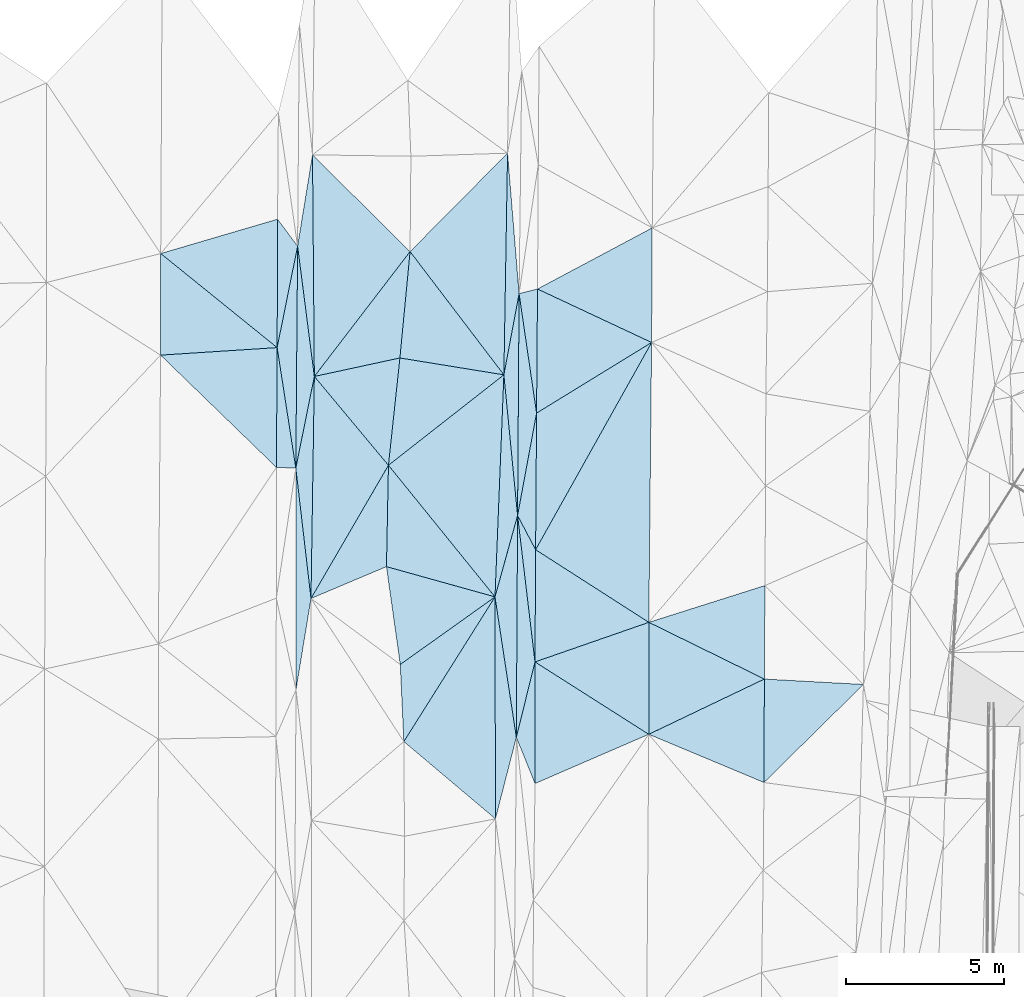
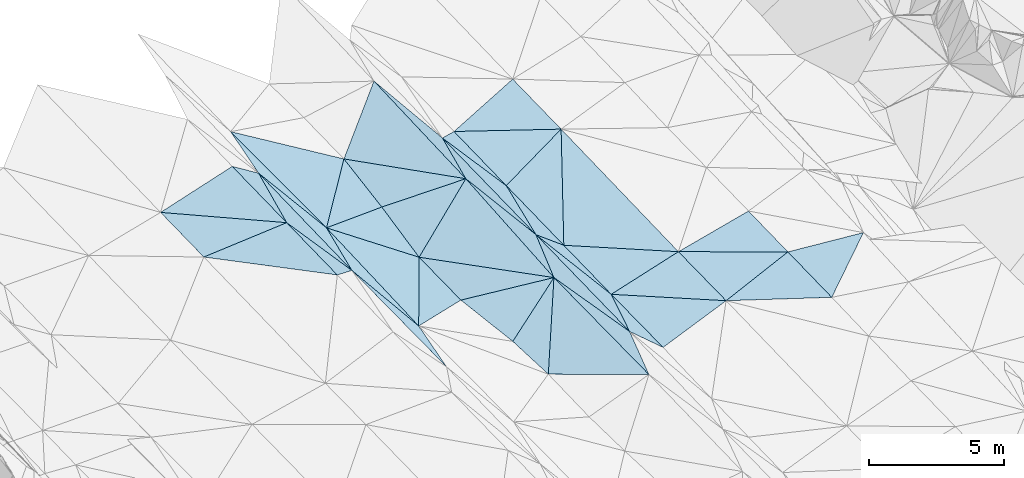
# One storey, part 148 of 275: 45 plates.
"""IFC2X3 building model written with IfcOpenShell, lengths in millimetres."""

from ifc_helpers import new_model, si_unit, frame, origin_with_axes, place, context, subcontext, project, spatial, polyline, outline, extrude, material, type_object, element, save


model = new_model("IFC2X3")

# Units and contexts
model_context = context("Model", 3, precision=1e-05, world=origin_with_axes())
body_context = subcontext(model_context, "Body", "Model", "MODEL_VIEW")
ifc_project = project(units=[si_unit("LENGTHUNIT", "METRE", prefix="MILLI"), si_unit("AREAUNIT", "SQUARE_METRE"), si_unit("VOLUMEUNIT", "CUBIC_METRE"), si_unit("MASSUNIT", "GRAM", prefix="KILO"), si_unit("TIMEUNIT", "SECOND"), si_unit("PLANEANGLEUNIT", "RADIAN"), si_unit("SOLIDANGLEUNIT", "STERADIAN"), si_unit("THERMODYNAMICTEMPERATUREUNIT", "DEGREE_CELSIUS"), si_unit("LUMINOUSINTENSITYUNIT", "LUMEN")], contexts=[model_context])

# Site, building, storey
site_placement = place(None, origin_with_axes())
site = spatial("IfcSite", under=ifc_project, at=site_placement, CompositionType="ELEMENT")
building_placement = place(site_placement, origin_with_axes())
building = spatial("IfcBuilding", under=site, at=building_placement, Name="Undefined", CompositionType="ELEMENT")
storey_placement = place(building_placement, origin_with_axes())
storey = spatial("IfcBuildingStorey", under=building, at=storey_placement, Name="Undefined", CompositionType="ELEMENT", Elevation=0.0)

# Plates
ifc_material = material()
plate_type_1 = type_object("IfcPlateType", PredefinedType="NOTDEFINED")
plate_1_placement = place(storey_placement, frame((-75964.6085799381, 115638.911751453, 43204.5066319559), z_axis=(0.160311117242028, 0.0261125572139905, -0.986721075098915), x_axis=(-0.0464081485364225, 0.998743920597506, 0.0188908660189011)))
element("IfcPlate", 1, at=plate_1_placement, inside=storey, type_object=plate_type_1, material=ifc_material, Name="00", context=body_context, shape_type="SweptSolid", body=[
    extrude(outline(polyline([(0.0, 0.0), (2435.03930664063, 3.14321368932724e-09), (4437.47998046875, 3125.26147460938), (0.0, 0.0)])), frame((-8.85201319254618e-08, 2.18876761149539e-07, -0.5000001331573), z_axis=(0.0, 0.0, 1.0), x_axis=(1.0, 0.0, 0.0)), (0.0, 0.0, 1.0), 1.0),
])
plate_type_2 = type_object("IfcPlateType", PredefinedType="NOTDEFINED")
plate_2_placement = place(storey_placement, frame((-79949.0426562773, 132120.246670613, 43989.5001166933), z_axis=(0.0107188924099907, 0.0197077235417985, -0.999748323818701), x_axis=(0.596220278596028, -0.802765477815505, -0.00943223295513346)))
element("IfcPlate", 2, at=plate_2_placement, inside=storey, type_object=plate_type_2, material=ifc_material, Name="00", context=body_context, shape_type="SweptSolid", body=[
    extrude(outline(polyline([(0.0, 0.0), (1060.1943359375, 1.47701939567924e-09), (3245.15991210938, 2426.48681640625), (0.0, 0.0)])), frame((-8.85201319254618e-08, 2.18876761149539e-07, -0.5000001331573), z_axis=(0.0, 0.0, 1.0), x_axis=(1.0, 0.0, 0.0)), (0.0, 0.0, 1.0), 1.0),
])
plate_type_3 = type_object("IfcPlateType", PredefinedType="NOTDEFINED")
plate_3_placement = place(storey_placement, frame((-79373.2008001047, 124268.647137265, 43851.5059641015), z_axis=(-0.152916196069069, 0.0192931900139735, -0.988050813368852), x_axis=(0.00802434047294629, 0.999800692518629, 0.0182807330062237)))
element("IfcPlate", 3, at=plate_3_placement, inside=storey, type_object=plate_type_3, material=ifc_material, Name="00", context=body_context, shape_type="SweptSolid", body=[
    extrude(outline(polyline([(0.0, 0.0), (7001.9072265625, -3.77476681023836e-08), (2893.5478515625, 567.798400878906), (0.0, 0.0)])), frame((-8.85201319254618e-08, 2.18876761149539e-07, -0.5000001331573), z_axis=(0.0, 0.0, 1.0), x_axis=(1.0, 0.0, 0.0)), (0.0, 0.0, 1.0), 1.0),
])
plate_type_4 = type_object("IfcPlateType", PredefinedType="NOTDEFINED")
plate_4_placement = place(storey_placement, frame((-61465.4492507407, 117441.521817981, 43429.500453023), z_axis=(-0.0371762981072988, 0.0215616423934602, -0.999076082406307), x_axis=(-0.712118536360222, -0.701967516282488, 0.0113488438340389)))
element("IfcPlate", 4, at=plate_4_placement, inside=storey, type_object=plate_type_4, material=ifc_material, Name="00", context=body_context, shape_type="SweptSolid", body=[
    extrude(outline(polyline([(0.0, 0.0), (4405.73486328125, -4.88944351673126e-09), (2107.61669921875, 2317.94140625), (0.0, 0.0)])), frame((-8.85201319254618e-08, 2.18876761149539e-07, -0.5000001331573), z_axis=(0.0, 0.0, 1.0), x_axis=(1.0, 0.0, 0.0)), (0.0, 0.0, 1.0), 1.0),
])
plate_type_5 = type_object("IfcPlateType", PredefinedType="NOTDEFINED")
plate_5_placement = place(storey_placement, frame((-73089.1088576157, 120204.461598305, 43792.5074478523), z_axis=(0.170969803398157, 0.0191893173481751, -0.985089384992908), x_axis=(0.00199426654865847, -0.999815014952442, -0.0191300490480677)))
element("IfcPlate", 5, at=plate_5_placement, inside=storey, type_object=plate_type_5, material=ifc_material, Name="00", context=body_context, shape_type="SweptSolid", body=[
    extrude(outline(polyline([(0.0, 0.0), (7004.68701171875, -2.03726813197136e-09), (4570.22265625, 2927.72143554688), (0.0, 0.0)])), frame((-8.85201319254618e-08, 2.18876761149539e-07, -0.5000001331573), z_axis=(0.0, 0.0, 1.0), x_axis=(1.0, 0.0, 0.0)), (0.0, 0.0, 1.0), 1.0),
])
plate_type_6 = type_object("IfcPlateType", PredefinedType="NOTDEFINED")
plate_6_placement = place(storey_placement, frame((-78894.5313013717, 120153.823342637, 43670.5076123488), z_axis=(-0.172369302595807, 0.0232650245499434, -0.984757615941774), x_axis=(-0.115441002584001, 0.992354758221715, 0.0436509880429174)))
element("IfcPlate", 6, at=plate_6_placement, inside=storey, type_object=plate_type_6, material=ifc_material, Name="00", context=body_context, shape_type="SweptSolid", body=[
    extrude(outline(polyline([(0.0, 0.0), (4146.52685546875, -1.03755155578256e-08), (6945.5498046875, 927.623901367188), (0.0, 0.0)])), frame((-8.85201319254618e-08, 2.18876761149539e-07, -0.5000001331573), z_axis=(0.0, 0.0, 1.0), x_axis=(1.0, 0.0, 0.0)), (0.0, 0.0, 1.0), 1.0),
])
plate_type_7 = type_object("IfcPlateType", PredefinedType="NOTDEFINED")
plate_7_placement = place(storey_placement, frame((-73075.1494270201, 113201.070515248, 43658.5058490175), z_axis=(0.151409707936762, 0.0192114338370893, -0.988284382732231), x_axis=(-0.00199426655382093, 0.999815014952867, 0.0191300490253277)))
element("IfcPlate", 7, at=plate_7_placement, inside=storey, type_object=plate_type_7, material=ifc_material, Name="00", context=body_context, shape_type="SweptSolid", body=[
    extrude(outline(polyline([(0.0, 0.0), (7004.68701171875, -2.03726813197136e-09), (2573.30517578125, 672.120849609375), (0.0, 0.0)])), frame((-8.85201319254618e-08, 2.18876761149539e-07, -0.5000001331573), z_axis=(0.0, 0.0, 1.0), x_axis=(1.0, 0.0, 0.0)), (0.0, 0.0, 1.0), 1.0),
])
plate_type_8 = type_object("IfcPlateType", PredefinedType="NOTDEFINED")
plate_8_placement = place(storey_placement, frame((-75768.9038775354, 131098.214744382, 43481.5047623022), z_axis=(-0.136421885507314, 0.0201039094927325, -0.990446819358686), x_axis=(-0.0950130144238929, -0.9954505776975, -0.00711859900528834)))
element("IfcPlate", 8, at=plate_8_placement, inside=storey, type_object=plate_type_8, material=ifc_material, Name="00", context=body_context, shape_type="SweptSolid", body=[
    extrude(outline(polyline([(0.0, 0.0), (3371.4501953125, -4.11091605201364e-08), (4206.13232421875, 2657.3095703125), (0.0, 0.0)])), frame((-8.85201319254618e-08, 2.18876761149539e-07, -0.5000001331573), z_axis=(0.0, 0.0, 1.0), x_axis=(1.0, 0.0, 0.0)), (0.0, 0.0, 1.0), 1.0),
])
plate_type_9 = type_object("IfcPlateType", PredefinedType="NOTDEFINED")
plate_9_placement = place(storey_placement, frame((-79962.0692561109, 128069.032459649, 43909.5001588285), z_axis=(0.0185385721528783, 0.0181294400737512, -0.999663765845869), x_axis=(0.197576974387605, 0.980052936997781, 0.0214378141111312)))
element("IfcPlate", 9, at=plate_9_placement, inside=storey, type_object=plate_type_9, material=ifc_material, Name="00", context=body_context, shape_type="SweptSolid", body=[
    extrude(outline(polyline([(0.0, 0.0), (3265.25830078125, -2.23953975364566e-08), (-3609.458984375, 1328.52172851563), (0.0, 0.0)])), frame((-8.85201319254618e-08, 2.18876761149539e-07, -0.5000001331573), z_axis=(0.0, 0.0, 1.0), x_axis=(1.0, 0.0, 0.0)), (0.0, 0.0, 1.0), 1.0),
])
plate_type_10 = type_object("IfcPlateType", PredefinedType="NOTDEFINED")
plate_10_placement = place(storey_placement, frame((-79373.1224767868, 124268.645420426, 43851.5000513203), z_axis=(0.00376379149675327, 0.0158428673054296, -0.999867409924492), x_axis=(-0.999504304823291, 0.0313125544503303, -0.0032662782343893)))
element("IfcPlate", 10, at=plate_10_placement, inside=storey, type_object=plate_type_10, material=ifc_material, Name="00", context=body_context, shape_type="SweptSolid", body=[
    extrude(outline(polyline([(0.0, 0.0), (612.317749023438, 1.97906047105789e-09), (707.472595214844, 3780.56176757813), (0.0, 0.0)])), frame((-8.85201319254618e-08, 2.18876761149539e-07, -0.5000001331573), z_axis=(0.0, 0.0, 1.0), x_axis=(1.0, 0.0, 0.0)), (0.0, 0.0, 1.0), 1.0),
])
plate_type_11 = type_object("IfcPlateType", PredefinedType="NOTDEFINED")
plate_11_placement = place(storey_placement, frame((-72415.9220485229, 115773.275830414, 43809.5042011195), z_axis=(0.128522121411978, 0.0157215837832188, -0.991582016835275), x_axis=(-0.150200479571258, 0.988648284212691, -0.00379289597366099)))
element("IfcPlate", 11, at=plate_11_placement, inside=storey, type_object=plate_type_11, material=ifc_material, Name="00", context=body_context, shape_type="SweptSolid", body=[
    extrude(outline(polyline([(0.0, 0.0), (4482.06298828125, -2.42289388552308e-08), (6911.564453125, 1098.82421875), (0.0, 0.0)])), frame((-8.85201319254618e-08, 2.18876761149539e-07, -0.5000001331573), z_axis=(0.0, 0.0, 1.0), x_axis=(1.0, 0.0, 0.0)), (0.0, 0.0, 1.0), 1.0),
])
plate_type_12 = type_object("IfcPlateType", PredefinedType="NOTDEFINED")
plate_12_placement = place(storey_placement, frame((-64591.3757210933, 117612.143186038, 43549.5006034403), z_axis=(-0.0463504255040148, 0.0172294288804646, -0.998776644118218), x_axis=(-0.896589428535813, 0.440121238522721, 0.0492005288493002)))
element("IfcPlate", 12, at=plate_12_placement, inside=storey, type_object=plate_type_12, material=ifc_material, Name="00", context=body_context, shape_type="SweptSolid", body=[
    extrude(outline(polyline([(0.0, 0.0), (4064.99682617188, -7.58154783397913e-09), (1283.59265136719, 2656.14184570313), (0.0, 0.0)])), frame((-8.85201319254618e-08, 2.18876761149539e-07, -0.5000001331573), z_axis=(0.0, 0.0, 1.0), x_axis=(1.0, 0.0, 0.0)), (0.0, 0.0, 1.0), 1.0),
])
plate_type_13 = type_object("IfcPlateType", PredefinedType="NOTDEFINED")
plate_13_placement = place(storey_placement, frame((-78788.8921198863, 127158.702057801, 43817.5079918876), z_axis=(-0.177453747484603, 0.0159807884179296, -0.983999381049202), x_axis=(-0.127340966591947, 0.991089579319265, 0.0390605170497022)))
element("IfcPlate", 13, at=plate_13_placement, inside=storey, type_object=plate_type_13, material=ifc_material, Name="00", context=body_context, shape_type="SweptSolid", body=[
    extrude(outline(polyline([(0.0, 0.0), (4147.41064453125, -1.61235220730305e-08), (6941.5234375, 846.419555664063), (0.0, 0.0)])), frame((-8.85201319254618e-08, 2.18876761149539e-07, -0.5000001331573), z_axis=(0.0, 0.0, 1.0), x_axis=(1.0, 0.0, 0.0)), (0.0, 0.0, 1.0), 1.0),
])
plate_type_14 = type_object("IfcPlateType", PredefinedType="NOTDEFINED")
plate_14_placement = place(storey_placement, frame((-71826.0999066617, 114315.297454092, 43769.5002039032), z_axis=(-0.0227321842608072, 0.0182261475188008, -0.999575437546039), x_axis=(-0.374942128649807, 0.92669952504087, 0.0254242099695789)))
element("IfcPlate", 14, at=plate_14_placement, inside=storey, type_object=plate_type_14, material=ifc_material, Name="00", context=body_context, shape_type="SweptSolid", body=[
    extrude(outline(polyline([(0.0, 0.0), (1573.30358886719, -6.50834408588707e-09), (3558.130859375, 1437.77746582031), (0.0, 0.0)])), frame((-8.85201319254618e-08, 2.18876761149539e-07, -0.5000001331573), z_axis=(0.0, 0.0, 1.0), x_axis=(1.0, 0.0, 0.0)), (0.0, 0.0, 1.0), 1.0),
])
plate_type_15 = type_object("IfcPlateType", PredefinedType="NOTDEFINED")
plate_15_placement = place(storey_placement, frame((-72376.8823979489, 122770.571091596, 43925.5071290616), z_axis=(0.167829921260686, 0.0132208340554135, -0.98572730867949), x_axis=(-0.0968393774931391, 0.995295073560578, -0.00313871196288268)))
element("IfcPlate", 15, at=plate_15_placement, inside=storey, type_object=plate_type_15, material=ifc_material, Name="00", context=body_context, shape_type="SweptSolid", body=[
    extrude(outline(polyline([(0.0, 0.0), (4460.42822265625, 1.20489858090878e-08), (6962.1513671875, 735.811279296875), (0.0, 0.0)])), frame((-8.85201319254618e-08, 2.18876761149539e-07, -0.5000001331573), z_axis=(0.0, 0.0, 1.0), x_axis=(1.0, 0.0, 0.0)), (0.0, 0.0, 1.0), 1.0),
])
plate_type_16 = type_object("IfcPlateType", PredefinedType="NOTDEFINED")
plate_16_placement = place(storey_placement, frame((-71777.7732432984, 126002.873903108, 43969.5002751759), z_axis=(-0.0293651859855547, 0.016434670180614, -0.999433633348452), x_axis=(0.852137708291904, 0.523059440249918, -0.0164361818091876)))
element("IfcPlate", 16, at=plate_16_placement, inside=storey, type_object=plate_type_16, material=ifc_material, Name="00", context=body_context, shape_type="SweptSolid", body=[
    extrude(outline(polyline([(0.0, 0.0), (4258.896484375, 8.55652615427971e-09), (-2278.66528320313, 3659.28735351563), (0.0, 0.0)])), frame((-8.85201319254618e-08, 2.18876761149539e-07, -0.5000001331573), z_axis=(0.0, 0.0, 1.0), x_axis=(1.0, 0.0, 0.0)), (0.0, 0.0, 1.0), 1.0),
])
plate_type_17 = type_object("IfcPlateType", PredefinedType="NOTDEFINED")
plate_17_placement = place(storey_placement, frame((-83640.1200700943, 127831.556536638, 43789.500351535), z_axis=(0.0311960132697812, 0.0217805417164945, -0.999275946252389), x_axis=(0.00132947239893295, 0.999760756135819, 0.0218326130794495)))
element("IfcPlate", 17, at=plate_17_placement, inside=storey, type_object=plate_type_17, material=ifc_material, Name="00", context=body_context, shape_type="SweptSolid", body=[
    extrude(outline(polyline([(0.0, 0.0), (3206.21264648438, -3.07045411318541e-09), (244.930725097656, 3679.52563476563), (0.0, 0.0)])), frame((-8.85201319254618e-08, 2.18876761149539e-07, -0.5000001331573), z_axis=(0.0, 0.0, 1.0), x_axis=(1.0, 0.0, 0.0)), (0.0, 0.0, 1.0), 1.0),
])
plate_type_18 = type_object("IfcPlateType", PredefinedType="NOTDEFINED")
plate_18_placement = place(storey_placement, frame((-79367.4838249951, 117271.463965401, 43737.5138296378), z_axis=(-0.233130912666591, 0.0156494813432342, -0.972319428630802), x_axis=(-0.000822662523326479, 0.99986696897134, 0.0162901070112496)))
element("IfcPlate", 18, at=plate_18_placement, inside=storey, type_object=plate_type_18, material=ifc_material, Name="00", context=body_context, shape_type="SweptSolid", body=[
    extrude(outline(polyline([(0.0, 0.0), (6998.1123046875, 8.67294147610664e-09), (2880.49169921875, 488.759582519531), (0.0, 0.0)])), frame((-8.85201319254618e-08, 2.18876761149539e-07, -0.5000001331573), z_axis=(0.0, 0.0, 1.0), x_axis=(1.0, 0.0, 0.0)), (0.0, 0.0, 1.0), 1.0),
])
plate_type_19 = type_object("IfcPlateType", PredefinedType="NOTDEFINED")
plate_19_placement = place(storey_placement, frame((-76451.2417965469, 124356.61452342, 43370.5031320291), z_axis=(-0.111855435825877, -0.00590563896405591, -0.993706941157517), x_axis=(-0.0194199834663504, -0.999778377736007, 0.00812770900838266)))
element("IfcPlate", 19, at=plate_19_placement, inside=storey, type_object=plate_type_19, material=ifc_material, Name="00", context=body_context, shape_type="SweptSolid", body=[
    extrude(outline(polyline([(0.0, 0.0), (3198.93359375, -5.95173332840204e-09), (4251.7607421875, 2376.05200195313), (0.0, 0.0)])), frame((-8.85201319254618e-08, 2.18876761149539e-07, -0.5000001331573), z_axis=(0.0, 0.0, 1.0), x_axis=(1.0, 0.0, 0.0)), (0.0, 0.0, 1.0), 1.0),
])
plate_type_20 = type_object("IfcPlateType", PredefinedType="NOTDEFINED")
plate_20_placement = place(storey_placement, frame((-72808.832522316, 127210.014423163, 43911.506314557), z_axis=(0.157800957975845, 0.0151729858909677, -0.987354363013127), x_axis=(0.0165626584465113, 0.999700618053251, 0.0180097920346795)))
element("IfcPlate", 20, at=plate_20_placement, inside=storey, type_object=plate_type_20, material=ifc_material, Name="00", context=body_context, shape_type="SweptSolid", body=[
    extrude(outline(polyline([(0.0, 0.0), (6996.1943359375, -3.03552951663733e-08), (2569.8447265625, 442.644866943359), (0.0, 0.0)])), frame((-8.85201319254618e-08, 2.18876761149539e-07, -0.5000001331573), z_axis=(0.0, 0.0, 1.0), x_axis=(1.0, 0.0, 0.0)), (0.0, 0.0, 1.0), 1.0),
])
plate_type_21 = type_object("IfcPlateType", PredefinedType="NOTDEFINED")
plate_21_placement = place(storey_placement, frame((-76451.266328458, 124356.629032718, 43370.5066437731), z_axis=(-0.160945902729907, 0.0231333417188723, -0.986692082108382), x_axis=(-0.501630467588923, -0.862886494312194, 0.0615936029156514)))
element("IfcPlate", 21, at=plate_21_placement, inside=storey, type_object=plate_type_21, material=ifc_material, Name="00", context=body_context, shape_type="SweptSolid", body=[
    extrude(outline(polyline([(0.0, 0.0), (4870.6357421875, -7.30506144464016e-09), (-1217.72155761719, 3468.86889648438), (0.0, 0.0)])), frame((-8.85201319254618e-08, 2.18876761149539e-07, -0.5000001331573), z_axis=(0.0, 0.0, 1.0), x_axis=(1.0, 0.0, 0.0)), (0.0, 0.0, 1.0), 1.0),
])
plate_type_22 = type_object("IfcPlateType", PredefinedType="NOTDEFINED")
plate_22_placement = place(storey_placement, frame((-71827.7001874498, 118152.300554699, 43839.5001079209), z_axis=(-0.0134356216420619, 0.017019341852163, -0.999764885397567), x_axis=(-0.118082142678342, 0.992831704866587, 0.0184881960233581)))
element("IfcPlate", 22, at=plate_22_placement, inside=storey, type_object=plate_type_22, material=ifc_material, Name="00", context=body_context, shape_type="SweptSolid", body=[
    extrude(outline(polyline([(0.0, 0.0), (4651.61669921875, 2.97222868539393e-08), (3513.830078125, 438.176544189453), (0.0, 0.0)])), frame((-8.85201319254618e-08, 2.18876761149539e-07, -0.5000001331573), z_axis=(0.0, 0.0, 1.0), x_axis=(1.0, 0.0, 0.0)), (0.0, 0.0, 1.0), 1.0),
])
plate_type_23 = type_object("IfcPlateType", PredefinedType="NOTDEFINED")
plate_23_placement = place(storey_placement, frame((-72415.9945219927, 115773.276307539, 43809.5001283121), z_axis=(-0.0164105123172665, 0.0166648085831141, -0.999726452205989), x_axis=(0.00557558541163701, 0.999847074511287, 0.0165752960317081)))
element("IfcPlate", 23, at=plate_23_placement, inside=storey, type_object=plate_type_23, material=ifc_material, Name="00", context=body_context, shape_type="SweptSolid", body=[
    extrude(outline(polyline([(0.0, 0.0), (6998.36669921875, 2.41852831095457e-08), (2382.4375, 575.095764160156), (0.0, 0.0)])), frame((-8.85201319254618e-08, 2.18876761149539e-07, -0.5000001331573), z_axis=(0.0, 0.0, 1.0), x_axis=(1.0, 0.0, 0.0)), (0.0, 0.0, 1.0), 1.0),
])
plate_type_24 = type_object("IfcPlateType", PredefinedType="NOTDEFINED")
plate_24_placement = place(storey_placement, frame((-72376.9690092833, 122770.571787361, 43925.5000509966), z_axis=(-0.00536853176521863, 0.0146061695926805, -0.999878912007107), x_axis=(0.00680707131388879, 0.999870688348775, 0.0145695010578362)))
element("IfcPlate", 24, at=plate_24_placement, inside=storey, type_object=plate_type_24, material=ifc_material, Name="00", context=body_context, shape_type="SweptSolid", body=[
    extrude(outline(polyline([(0.0, 0.0), (7000.92626953125, 1.45519152283669e-10), (3236.60302734375, 577.197692871094), (0.0, 0.0)])), frame((-8.85201319254618e-08, 2.18876761149539e-07, -0.5000001331573), z_axis=(0.0, 0.0, 1.0), x_axis=(1.0, 0.0, 0.0)), (0.0, 0.0, 1.0), 1.0),
])
plate_25_placement = place(storey_placement, frame((-71807.5502662731, 121692.779553267, 43899.5001114203), z_axis=(-0.014723503398036, 0.0163387600441146, -0.999758102426737), x_axis=(-0.467029746609632, 0.88398443070093, 0.0213246819459599)))
element("IfcPlate", 25, at=plate_25_placement, inside=storey, type_object=plate_type_24, material=ifc_material, Name="00", context=body_context, shape_type="SweptSolid", body=[
    extrude(outline(polyline([(0.0, 0.0), (1219.24438476563, 8.54561221785843e-09), (3797.63891601563, 2039.76452636719), (0.0, 0.0)])), frame((-8.85201319254618e-08, 2.18876761149539e-07, -0.5000001331573), z_axis=(0.0, 0.0, 1.0), x_axis=(1.0, 0.0, 0.0)), (0.0, 0.0, 1.0), 1.0),
])
plate_type_25 = type_object("IfcPlateType", PredefinedType="NOTDEFINED")
plate_26_placement = place(storey_placement, frame((-71777.758788468, 126002.87334911, 43969.5000495108), z_axis=(-0.000449199901370127, 0.0153263590111527, -0.999882443559697), x_axis=(-0.144828230687063, 0.989339595966767, 0.0152298210222215)))
element("IfcPlate", 26, at=plate_26_placement, inside=storey, type_object=plate_type_25, material=ifc_material, Name="00", context=body_context, shape_type="SweptSolid", body=[
    extrude(outline(polyline([(0.0, 0.0), (3808.31811523438, 1.15105649456382e-08), (3870.14184570313, 596.20703125), (0.0, 0.0)])), frame((-8.85201319254618e-08, 2.18876761149539e-07, -0.5000001331573), z_axis=(0.0, 0.0, 1.0), x_axis=(1.0, 0.0, 0.0)), (0.0, 0.0, 1.0), 1.0),
])
plate_type_26 = type_object("IfcPlateType", PredefinedType="NOTDEFINED")
plate_27_placement = place(storey_placement, frame((-72808.8433447673, 127210.003887101, 43911.5046504325), z_axis=(0.136153712457608, -0.00591108420638689, -0.990670089216141), x_axis=(-0.978013343408387, 0.158642220557511, -0.135360799243103)))
element("IfcPlate", 27, at=plate_27_placement, inside=storey, type_object=plate_type_26, material=ifc_material, Name="00", context=body_context, shape_type="SweptSolid", body=[
    extrude(outline(polyline([(0.0, 0.0), (3353.9990234375, 4.93309926241636e-09), (3569.8828125, 3364.53125), (0.0, 0.0)])), frame((-8.85201319254618e-08, 2.18876761149539e-07, -0.5000001331573), z_axis=(0.0, 0.0, 1.0), x_axis=(1.0, 0.0, 0.0)), (0.0, 0.0, 1.0), 1.0),
])
plate_type_27 = type_object("IfcPlateType", PredefinedType="NOTDEFINED")
plate_28_placement = place(storey_placement, frame((-76451.1164721681, 124356.622768869, 43370.5048584007), z_axis=(0.138777435355456, 0.0106080243976515, -0.9902667788301), x_axis=(0.106291993425683, 0.994006798764558, 0.0255440040602442)))
element("IfcPlate", 28, at=plate_28_placement, inside=storey, type_object=plate_type_27, material=ifc_material, Name="00", context=body_context, shape_type="SweptSolid", body=[
    extrude(outline(polyline([(0.0, 0.0), (3405.88745117188, -2.06782715395093e-08), (3237.25244140625, 3349.75708007813), (0.0, 0.0)])), frame((-8.85201319254618e-08, 2.18876761149539e-07, -0.5000001331573), z_axis=(0.0, 0.0, 1.0), x_axis=(1.0, 0.0, 0.0)), (0.0, 0.0, 1.0), 1.0),
])
plate_type_28 = type_object("IfcPlateType", PredefinedType="NOTDEFINED")
plate_29_placement = place(storey_placement, frame((-79962.0627296685, 128069.031227879, 43909.5003015784), z_axis=(0.0315941760712451, 0.0156653760038373, -0.999378008579855), x_axis=(-0.0060977003990024, -0.999855539433941, -0.0158656330824405)))
element("IfcPlate", 29, at=plate_29_placement, inside=storey, type_object=plate_type_28, material=ifc_material, Name="00", context=body_context, shape_type="SweptSolid", body=[
    extrude(outline(polyline([(0.0, 0.0), (3781.75903320313, 3.91446519643068e-09), (261.775024414063, 3678.36572265625), (0.0, 0.0)])), frame((-8.85201319254618e-08, 2.18876761149539e-07, -0.5000001331573), z_axis=(0.0, 0.0, 1.0), x_axis=(1.0, 0.0, 0.0)), (0.0, 0.0, 1.0), 1.0),
])
plate_type_29 = type_object("IfcPlateType", PredefinedType="NOTDEFINED")
plate_30_placement = place(storey_placement, frame((-75768.9015416482, 131098.212927766, 43481.5044193344), z_axis=(-0.131779808690708, 0.0164860799592057, -0.991141912739553), x_axis=(-0.607001468693959, -0.791825919451025, 0.067534659908199)))
element("IfcPlate", 30, at=plate_30_placement, inside=storey, type_object=plate_type_29, material=ifc_material, Name="00", context=body_context, shape_type="SweptSolid", body=[
    extrude(outline(polyline([(0.0, 0.0), (4975.22314453125, -4.83123585581779e-09), (-517.35107421875, 4328.14111328125), (0.0, 0.0)])), frame((-8.85201319254618e-08, 2.18876761149539e-07, -0.5000001331573), z_axis=(0.0, 0.0, 1.0), x_axis=(1.0, 0.0, 0.0)), (0.0, 0.0, 1.0), 1.0),
])
plate_type_30 = type_object("IfcPlateType", PredefinedType="NOTDEFINED")
plate_31_placement = place(storey_placement, frame((-68128.9172535333, 131846.247652475, 43959.5002612602), z_axis=(-0.0282468214148503, 0.0167390844936343, -0.999460814704745), x_axis=(-0.00544458230507501, -0.999847524614493, -0.0165916860443618)))
element("IfcPlate", 31, at=plate_31_placement, inside=storey, type_object=plate_type_30, material=ifc_material, Name="00", context=body_context, shape_type="SweptSolid", body=[
    extrude(outline(polyline([(0.0, 0.0), (3616.26904296875, -2.38651409745216e-09), (1946.3984375, 3610.3369140625), (0.0, 0.0)])), frame((-8.85201319254618e-08, 2.18876761149539e-07, -0.5000001331573), z_axis=(0.0, 0.0, 1.0), x_axis=(1.0, 0.0, 0.0)), (0.0, 0.0, 1.0), 1.0),
])
plate_type_31 = type_object("IfcPlateType", PredefinedType="NOTDEFINED")
plate_32_placement = place(storey_placement, frame((-71827.7094365346, 118152.301954699, 43839.5003436532), z_axis=(-0.0319317569528243, 0.0198193970903923, -0.999293527646847), x_axis=(0.944261378615365, 0.328345251588882, -0.0236610357855293)))
element("IfcPlate", 32, at=plate_32_placement, inside=storey, type_object=plate_type_31, material=ifc_material, Name="00", context=body_context, shape_type="SweptSolid", body=[
    extrude(outline(polyline([(0.0, 0.0), (3803.72192382813, -8.76025296747684e-09), (2643.77905273438, 3337.24926757813), (0.0, 0.0)])), frame((-8.85201319254618e-08, 2.18876761149539e-07, -0.5000001331573), z_axis=(0.0, 0.0, 1.0), x_axis=(1.0, 0.0, 0.0)), (0.0, 0.0, 1.0), 1.0),
])
plate_type_32 = type_object("IfcPlateType", PredefinedType="NOTDEFINED")
plate_33_placement = place(storey_placement, frame((-64591.3755057845, 117612.145363207, 43549.5006345487), z_axis=(-0.0459238652794353, 0.0215846092120441, -0.998711721791108), x_axis=(-0.00351817834889127, -0.999763827063435, -0.0214455710248069)))
element("IfcPlate", 33, at=plate_33_placement, inside=storey, type_object=plate_type_32, material=ifc_material, Name="00", context=body_context, shape_type="SweptSolid", body=[
    extrude(outline(polyline([(0.0, 0.0), (3264.0771484375, -6.53380993753672e-09), (1752.93029785156, 3644.19189453125), (0.0, 0.0)])), frame((-8.85201319254618e-08, 2.18876761149539e-07, -0.5000001331573), z_axis=(0.0, 0.0, 1.0), x_axis=(1.0, 0.0, 0.0)), (0.0, 0.0, 1.0), 1.0),
])
plate_type_33 = type_object("IfcPlateType", PredefinedType="NOTDEFINED")
plate_34_placement = place(storey_placement, frame((-68237.866778851, 115868.843490012, 43679.500596241), z_axis=(-0.0450811415631103, 0.0198162730074597, -0.998786767032614), x_axis=(0.000526005334691578, 0.999803570726913, 0.0198127050173015)))
element("IfcPlate", 34, at=plate_34_placement, inside=storey, type_object=plate_type_33, material=ifc_material, Name="00", context=body_context, shape_type="SweptSolid", body=[
    extrude(outline(polyline([(0.0, 0.0), (3533.08642578125, 1.99361238628626e-09), (1742.30102539063, 3649.28588867188), (0.0, 0.0)])), frame((-8.85201319254618e-08, 2.18876761149539e-07, -0.5000001331573), z_axis=(0.0, 0.0, 1.0), x_axis=(1.0, 0.0, 0.0)), (0.0, 0.0, 1.0), 1.0),
])
plate_type_34 = type_object("IfcPlateType", PredefinedType="NOTDEFINED")
plate_35_placement = place(storey_placement, frame((-71748.357738602, 129918.099593008, 44029.5002586997), z_axis=(-0.0288123366148301, 0.015533041885411, -0.999464143363122), x_axis=(0.904957219643913, -0.424245642541763, -0.0326812698450535)))
element("IfcPlate", 35, at=plate_35_placement, inside=storey, type_object=plate_type_34, material=ifc_material, Name="00", context=body_context, shape_type="SweptSolid", body=[
    extrude(outline(polyline([(0.0, 0.0), (3977.8134765625, 2.1260348148644e-08), (1636.35900878906, 3557.49780273438), (0.0, 0.0)])), frame((-8.85201319254618e-08, 2.18876761149539e-07, -0.5000001331573), z_axis=(0.0, 0.0, 1.0), x_axis=(1.0, 0.0, 0.0)), (0.0, 0.0, 1.0), 1.0),
])
plate_type_35 = type_object("IfcPlateType", PredefinedType="NOTDEFINED")
plate_36_placement = place(storey_placement, frame((-68236.0013176299, 119401.23461126, 43749.5003046734), z_axis=(-0.0309925342273404, 0.0171126278214915, -0.999373113902515), x_axis=(-0.944261378613199, -0.328345251595285, 0.0236610357831056)))
element("IfcPlate", 36, at=plate_36_placement, inside=storey, type_object=plate_type_35, material=ifc_material, Name="00", context=body_context, shape_type="SweptSolid", body=[
    extrude(outline(polyline([(0.0, 0.0), (3803.72192382813, -8.76025296747684e-09), (2623.61450195313, 3338.61450195313), (0.0, 0.0)])), frame((-8.85201319254618e-08, 2.18876761149539e-07, -0.5000001331573), z_axis=(0.0, 0.0, 1.0), x_axis=(1.0, 0.0, 0.0)), (0.0, 0.0, 1.0), 1.0),
])
plate_type_36 = type_object("IfcPlateType", PredefinedType="NOTDEFINED")
plate_37_placement = place(storey_placement, frame((-68237.860722365, 115868.842693009, 43679.5003452182), z_axis=(-0.0329511081906019, 0.0182166828208163, -0.999290937082898), x_axis=(-0.917439534722194, -0.397209249625902, 0.0230111307925626)))
element("IfcPlate", 37, at=plate_37_placement, inside=storey, type_object=plate_type_36, material=ifc_material, Name="00", context=body_context, shape_type="SweptSolid", body=[
    extrude(outline(polyline([(0.0, 0.0), (3911.15063476563, 1.39698386192322e-09), (2390.140625, 3523.35473632813), (0.0, 0.0)])), frame((-8.85201319254618e-08, 2.18876761149539e-07, -0.5000001331573), z_axis=(0.0, 0.0, 1.0), x_axis=(1.0, 0.0, 0.0)), (0.0, 0.0, 1.0), 1.0),
])
plate_type_37 = type_object("IfcPlateType", PredefinedType="NOTDEFINED")
plate_38_placement = place(storey_placement, frame((-72808.8422953655, 127210.012480411, 43911.5048270743), z_axis=(0.13825216049256, 0.0112910213767069, -0.990332698114836), x_axis=(-0.0399709294294283, -0.99905671862559, -0.0169704970350373)))
element("IfcPlate", 38, at=plate_38_placement, inside=storey, type_object=plate_type_37, material=ifc_material, Name="00", context=body_context, shape_type="SweptSolid", body=[
    extrude(outline(polyline([(0.0, 0.0), (7012.16943359375, -2.33703758567572e-08), (3005.4638671875, 3559.19384765625), (0.0, 0.0)])), frame((-8.85201319254618e-08, 2.18876761149539e-07, -0.5000001331573), z_axis=(0.0, 0.0, 1.0), x_axis=(1.0, 0.0, 0.0)), (0.0, 0.0, 1.0), 1.0),
])
plate_type_38 = type_object("IfcPlateType", PredefinedType="NOTDEFINED")
plate_39_placement = place(storey_placement, frame((-76077.6280888489, 118070.912061178, 43250.5054844097), z_axis=(0.132620338975293, 0.0654784567425331, -0.98900172769955), x_axis=(-0.139552619492549, 0.989109408744624, 0.0467722559390494)))
element("IfcPlate", 39, at=plate_39_placement, inside=storey, type_object=plate_type_38, material=ifc_material, Name="00", context=body_context, shape_type="SweptSolid", body=[
    extrude(outline(polyline([(0.0, 0.0), (3121.50854492188, 1.24418875202537e-08), (1718.63439941406, 3289.88208007813), (0.0, 0.0)])), frame((-8.85201319254618e-08, 2.18876761149539e-07, -0.5000001331573), z_axis=(0.0, 0.0, 1.0), x_axis=(1.0, 0.0, 0.0)), (0.0, 0.0, 1.0), 1.0),
])
plate_type_39 = type_object("IfcPlateType", PredefinedType="NOTDEFINED")
plate_40_placement = place(storey_placement, frame((-68148.6076382944, 128230.530383963, 43899.5003060586), z_axis=(-0.0308826398365143, 0.0172839363770436, -0.999373567841397), x_axis=(-0.00989622941133542, -0.999806758091306, -0.0169856150430351)))
element("IfcPlate", 40, at=plate_40_placement, inside=storey, type_object=plate_type_39, material=ifc_material, Name="00", context=body_context, shape_type="SweptSolid", body=[
    extrude(outline(polyline([(0.0, 0.0), (8831.001953125, 4.99858288094401e-08), (6572.69677734375, 3595.79711914063), (0.0, 0.0)])), frame((-8.85201319254618e-08, 2.18876761149539e-07, -0.5000001331573), z_axis=(0.0, 0.0, 1.0), x_axis=(1.0, 0.0, 0.0)), (0.0, 0.0, 1.0), 1.0),
])
plate_type_40 = type_object("IfcPlateType", PredefinedType="NOTDEFINED")
plate_41_placement = place(storey_placement, frame((-83635.8583611517, 131037.001118848, 43859.5003035926), z_axis=(0.0294680415635313, 0.0196400016897653, -0.99937275571232), x_axis=(0.958895419932899, 0.281738120593539, 0.0338113152085144)))
element("IfcPlate", 41, at=plate_41_placement, inside=storey, type_object=plate_type_40, material=ifc_material, Name="00", context=body_context, shape_type="SweptSolid", body=[
    extrude(outline(polyline([(0.0, 0.0), (3844.86669921875, -9.02218744158745e-10), (2688.28564453125, 3883.45458984375), (0.0, 0.0)])), frame((-8.85201319254618e-08, 2.18876761149539e-07, -0.5000001331573), z_axis=(0.0, 0.0, 1.0), x_axis=(1.0, 0.0, 0.0)), (0.0, 0.0, 1.0), 1.0),
])
plate_type_41 = type_object("IfcPlateType", PredefinedType="NOTDEFINED")
plate_42_placement = place(storey_placement, frame((-73089.1217842834, 120204.457506763, 43792.505314958), z_axis=(0.145118685685836, 0.0109996610313399, -0.989353109118282), x_axis=(0.0399709294309079, 0.999056718625604, 0.0169704970307135)))
element("IfcPlate", 42, at=plate_42_placement, inside=storey, type_object=plate_type_41, material=ifc_material, Name="00", context=body_context, shape_type="SweptSolid", body=[
    extrude(outline(polyline([(0.0, 0.0), (7012.16943359375, -2.33703758567572e-08), (2594.41748046875, 615.539855957031), (0.0, 0.0)])), frame((-8.85201319254618e-08, 2.18876761149539e-07, -0.5000001331573), z_axis=(0.0, 0.0, 1.0), x_axis=(1.0, 0.0, 0.0)), (0.0, 0.0, 1.0), 1.0),
])
plate_type_42 = type_object("IfcPlateType", PredefinedType="NOTDEFINED")
plate_43_placement = place(storey_placement, frame((-72692.9542962879, 134204.11394454, 44037.5067470662), z_axis=(0.163107387555954, 0.0150695574886216, -0.986493227833708), x_axis=(-0.0165626584490813, -0.999700618053046, -0.0180097920436682)))
element("IfcPlate", 43, at=plate_43_placement, inside=storey, type_object=plate_type_42, material=ifc_material, Name="00", context=body_context, shape_type="SweptSolid", body=[
    extrude(outline(polyline([(0.0, 0.0), (6996.1943359375, -3.03552951663733e-08), (3165.9287109375, 3064.8330078125), (0.0, 0.0)])), frame((-8.85201319254618e-08, 2.18876761149539e-07, -0.5000001331573), z_axis=(0.0, 0.0, 1.0), x_axis=(1.0, 0.0, 0.0)), (0.0, 0.0, 1.0), 1.0),
])
plate_type_43 = type_object("IfcPlateType", PredefinedType="NOTDEFINED")
plate_44_placement = place(storey_placement, frame((-73089.1383140226, 120204.446875961, 43792.5031688924), z_axis=(0.112058931020241, -0.0102545416765923, -0.99364865035565), x_axis=(-0.957391558371276, 0.266724387546897, -0.110722649205806)))
element("IfcPlate", 44, at=plate_44_placement, inside=storey, type_object=plate_type_43, material=ifc_material, Name="00", context=body_context, shape_type="SweptSolid", body=[
    extrude(outline(polyline([(0.0, 0.0), (3576.50390625, 7.05767888575792e-09), (4372.951171875, 3098.20068359375), (0.0, 0.0)])), frame((-8.85201319254618e-08, 2.18876761149539e-07, -0.5000001331573), z_axis=(0.0, 0.0, 1.0), x_axis=(1.0, 0.0, 0.0)), (0.0, 0.0, 1.0), 1.0),
])
plate_type_44 = type_object("IfcPlateType", PredefinedType="NOTDEFINED")
plate_45_placement = place(storey_placement, frame((-78788.8737221452, 127158.714298426, 43817.5053760815), z_axis=(-0.140659259445165, 0.0404623695315096, -0.989230897912228), x_axis=(0.969238476236055, 0.209455045600677, -0.129249216848799)))
element("IfcPlate", 45, at=plate_45_placement, inside=storey, type_object=plate_type_44, material=ifc_material, Name="00", context=body_context, shape_type="SweptSolid", body=[
    extrude(outline(polyline([(0.0, 0.0), (2785.31665039063, 1.27765815705061e-08), (1736.57421875, 3240.40258789063), (0.0, 0.0)])), frame((-8.85201319254618e-08, 2.18876761149539e-07, -0.5000001331573), z_axis=(0.0, 0.0, 1.0), x_axis=(1.0, 0.0, 0.0)), (0.0, 0.0, 1.0), 1.0),
])

save(model, "model.ifc")
